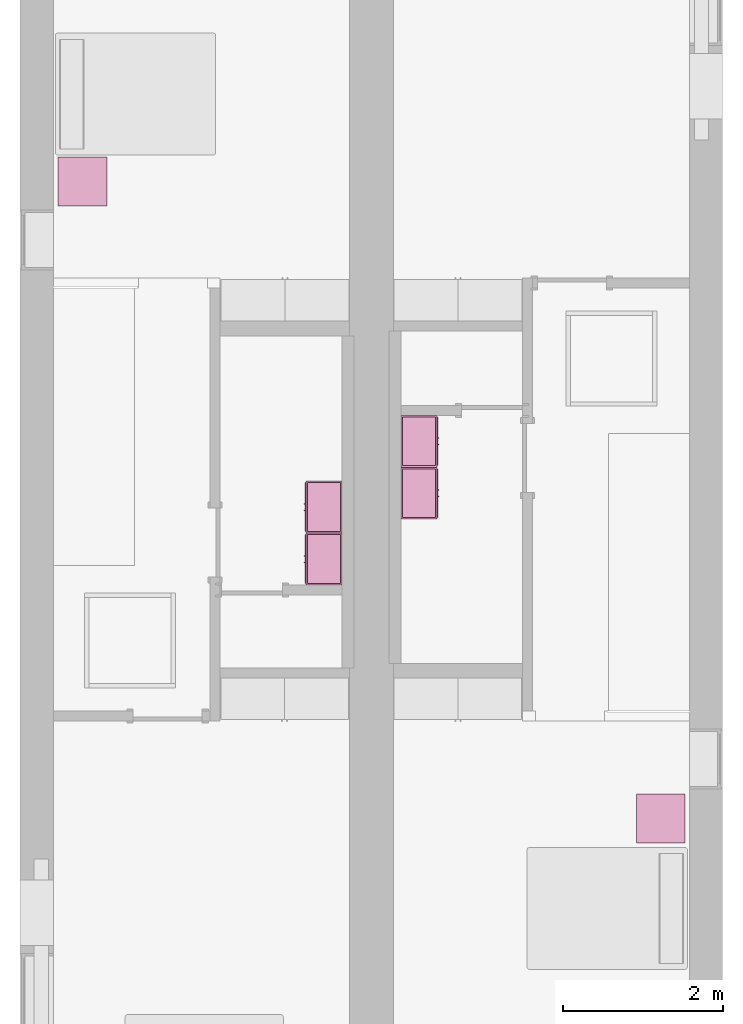
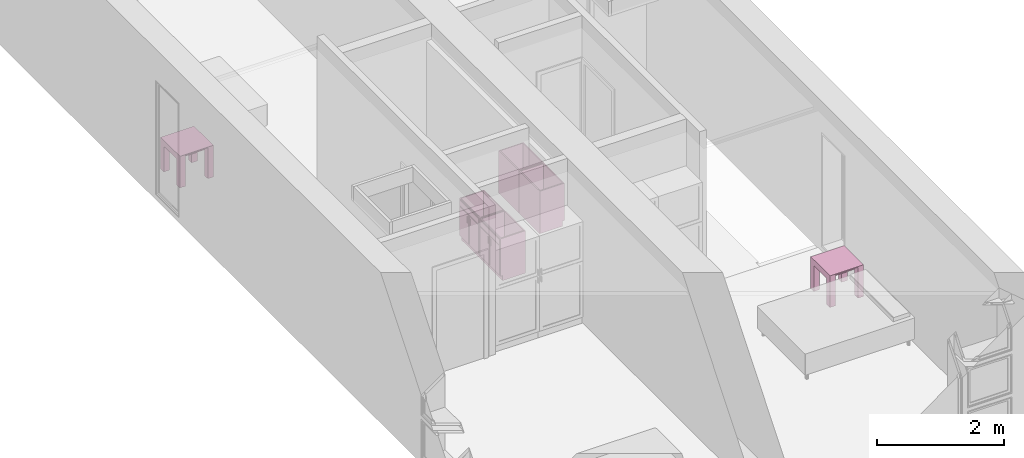
# One storey, part 8 of 12: 6 furnishings.
"""IFC2X3 building model written with IfcOpenShell, lengths in metres."""

import ifcopenshell
import ifcopenshell.guid

model = None  # the IFC model being written
_history = None  # IfcOwnerHistory: only IFC2X3 demands one
_inside = {}  # id of a spatial element -> (the spatial element, [elements in it])
_under = {}  # id of a project, library or spatial element -> (it, [spatial elements below it])
_declared = {}  # id of a project -> (the project, [libraries it declares])
_typed = {}  # id of a type object -> (the type object, [elements of that type])
_made_of = {}  # id of a material, layer set ... -> (it, [elements and type objects made of it])


def new_model(schema):
    """Start an empty IFC model of exactly this schema.

    Asked for "IFC4X3", IfcOpenShell would pick the latest addendum, in which some entities
    have other attributes; the version numbers below select the first issue.
    IFC2X3 requires an IfcOwnerHistory on every rooted entity: one is made here for all.
    """
    global model, _history
    if schema == "IFC4X3":
        model = ifcopenshell.file(schema_version=(4, 3, 0, 0))
    else:
        model = ifcopenshell.file(schema=schema)
    _inside.clear()
    _under.clear()
    _declared.clear()
    _typed.clear()
    _made_of.clear()
    _history = None
    if model.schema == "IFC2X3":
        org = make("IfcOrganization", Name="unknown")
        user = make(
            "IfcPersonAndOrganization",
            ThePerson=make("IfcPerson", FamilyName="unknown"),
            TheOrganization=org,
        )
        app = make(
            "IfcApplication",
            ApplicationDeveloper=org,
            Version="unknown",
            ApplicationFullName="unknown",
            ApplicationIdentifier="unknown",
        )
        _history = make(
            "IfcOwnerHistory",
            OwningUser=user,
            OwningApplication=app,
            ChangeAction="ADDED",
            CreationDate=0,
        )
    return model


def make(cls, **values):
    """One entity of the class cls with the attributes given. An attribute that is None is left unset."""
    return model.create_entity(
        cls, **{name: value for name, value in values.items() if value is not None}
    )


def entity(cls, *values):
    """Any entity or typed value of the class cls, its attributes in the order of the schema. None: left unset."""
    e = model.create_entity(cls)
    for i, value in enumerate(values):
        if value is not None:
            e[i] = value
    return e


def rooted(cls, **values):
    """An entity with a GlobalId (a new one), such as an element, a storey or a relation."""
    return make(cls, GlobalId=ifcopenshell.guid.new(), OwnerHistory=_history, **values)


def si_unit(unit_type, name, prefix=None):
    """IfcSIUnit, for example si_unit("LENGTHUNIT", "METRE", prefix="MILLI")."""
    return make("IfcSIUnit", UnitType=unit_type, Prefix=prefix, Name=name)


def converted_unit(unit_type, name, factor, base, dimensions=None, offset=None):
    """IfcConversionBasedUnit, such as the inch: factor (a typed value) times the base unit."""
    return make(
        "IfcConversionBasedUnit"
        if offset is None
        else "IfcConversionBasedUnitWithOffset",
        ConversionOffset=offset,
        Dimensions=None
        if dimensions is None
        else entity("IfcDimensionalExponents", *dimensions),
        UnitType=unit_type,
        Name=name,
        ConversionFactor=make(
            "IfcMeasureWithUnit", ValueComponent=factor, UnitComponent=base
        ),
    )


def assignment(units):
    """IfcUnitAssignment: the units of a project."""
    return None if units is None else make("IfcUnitAssignment", Units=units)


def point(xyz):
    """IfcCartesianPoint."""
    return None if xyz is None else make("IfcCartesianPoint", Coordinates=xyz)


def direction(xyz):
    """IfcDirection."""
    return None if xyz is None else make("IfcDirection", DirectionRatios=xyz)


def frame(location, z_axis=None, x_axis=None):
    """IfcAxis2Placement3D, a coordinate frame: its origin and axes. An axis left out is left unset."""
    return make(
        "IfcAxis2Placement3D",
        Location=point(location),
        Axis=direction(z_axis),
        RefDirection=direction(x_axis),
    )


def frame_2d(location, x_axis=None):
    """IfcAxis2Placement2D, a coordinate frame in the plane: its origin and x axis."""
    return make(
        "IfcAxis2Placement2D", Location=point(location), RefDirection=direction(x_axis)
    )


def origin():
    """The frame at (0, 0, 0) with its axes left unset."""
    return frame((0.0, 0.0, 0.0))


def origin_2d_with_axis():
    """The frame at (0, 0) in the plane with the x axis (1, 0) written out."""
    return frame_2d((0.0, 0.0), x_axis=(1.0, 0.0))


def place(relative_to, where):
    """IfcLocalPlacement: puts the frame where relative to a parent placement (None: the world)."""
    return make(
        "IfcLocalPlacement", PlacementRelTo=relative_to, RelativePlacement=where
    )


def context(
    kind, dimensions, precision=None, world=None, true_north=None, identifier=None
):
    """IfcGeometricRepresentationContext, for example the 3D "Model" context."""
    return make(
        "IfcGeometricRepresentationContext",
        ContextIdentifier=identifier,
        ContextType=kind,
        CoordinateSpaceDimension=dimensions,
        Precision=precision,
        WorldCoordinateSystem=world,
        TrueNorth=true_north,
    )


def project(units=None, contexts=None):
    """IfcProject with its units and contexts."""
    return rooted(
        "IfcProject",
        Name="project",
        RepresentationContexts=contexts,
        UnitsInContext=assignment(units),
    )


def spatial(cls, under=None, at=None, **own):
    """A site, building, storey or space (cls), placed at a placement, below another one or the project."""
    s = rooted(cls, ObjectPlacement=at, **own)
    if under is not None:
        _under.setdefault(under.id(), (under, []))[1].append(s)
    return s


def polyline(points):
    """IfcPolyline through the points."""
    return make("IfcPolyline", Points=[point(p) for p in points])


def profile(cls, at=None, kind="AREA", **sizes):
    """A parametric profile (cls). Its sizes go by their IFC names, for example OverallWidth=200.0."""
    return make(cls, ProfileType=kind, Position=at, **sizes)


def rectangle(**sizes):
    """IfcRectangleProfileDef."""
    return profile("IfcRectangleProfileDef", **sizes)


def outline(outer, holes=None, kind="AREA"):
    """IfcArbitraryClosedProfileDef: a profile drawn as a closed curve; with holes, ...WithVoids."""
    if holes is None:
        return make("IfcArbitraryClosedProfileDef", ProfileType=kind, OuterCurve=outer)
    return make(
        "IfcArbitraryProfileDefWithVoids",
        ProfileType=kind,
        OuterCurve=outer,
        InnerCurves=holes,
    )


def extrude(swept, where, along, depth):
    """IfcExtrudedAreaSolid: the profile swept, set in the frame where, extruded along a direction by depth."""
    return make(
        "IfcExtrudedAreaSolid",
        SweptArea=swept,
        Position=where,
        ExtrudedDirection=direction(along),
        Depth=depth,
    )


def faces_of(points, faces, orient=None, outer=None):
    """IfcFace entities. A face is a list of loops; a loop is a list of indices into points, from 0.

    orient and outer hold one flag for each loop. By default every Orientation is true, the
    first loop of a face is its IfcFaceOuterBound and the others are IfcFaceBound.
    """
    made = []
    for i, loops in enumerate(faces):
        bounds = []
        for j, loop in enumerate(loops):
            is_outer = j == 0 if outer is None else outer[i][j]
            bounds.append(
                make(
                    "IfcFaceOuterBound" if is_outer else "IfcFaceBound",
                    Bound=make("IfcPolyLoop", Polygon=[points[k] for k in loop]),
                    Orientation=True if orient is None else orient[i][j],
                )
            )
        made.append(make("IfcFace", Bounds=bounds))
    return made


def face_set(faces, orient=None, outer=None):
    """The faces of one IfcConnectedFaceSet. surface_model builds it on its shared points."""
    return ("IfcConnectedFaceSet", faces, orient, outer)


def surface_model(cls, points, shells):
    """IfcFaceBasedSurfaceModel or IfcShellBasedSurfaceModel (cls): surfaces that need not close."""
    shared = [point(p) for p in points]
    made = [make(c, CfsFaces=faces_of(shared, fs, o, b)) for c, fs, o, b in shells]
    if cls == "IfcFaceBasedSurfaceModel":
        return make(cls, FbsmFaces=made)
    return make(cls, SbsmBoundary=made)


def shape(context_of_items, identifier, shape_type, items):
    """IfcShapeRepresentation: the items that make up one representation, for example the "Body"."""
    return make(
        "IfcShapeRepresentation",
        ContextOfItems=context_of_items,
        RepresentationIdentifier=identifier,
        RepresentationType=shape_type,
        Items=items,
    )


def source(mapping_origin, context_of_items, identifier, shape_type, items):
    """IfcRepresentationMap: a shape defined once, which mapped items show again and again."""
    return make(
        "IfcRepresentationMap",
        MappingOrigin=mapping_origin,
        MappedRepresentation=shape(context_of_items, identifier, shape_type, items),
    )


def transform(
    local_origin,
    x_axis=None,
    y_axis=None,
    z_axis=None,
    scale=None,
    scale2=None,
    scale3=None,
    uniform=True,
):
    """IfcCartesianTransformationOperator3D, or its non-uniform kind. x_axis, y_axis, z_axis: its Axis1, 2, 3."""
    if uniform:
        return make(
            "IfcCartesianTransformationOperator3D",
            Axis1=direction(x_axis),
            Axis2=direction(y_axis),
            LocalOrigin=point(local_origin),
            Scale=scale,
            Axis3=direction(z_axis),
        )
    return make(
        "IfcCartesianTransformationOperator3DnonUniform",
        Axis1=direction(x_axis),
        Axis2=direction(y_axis),
        LocalOrigin=point(local_origin),
        Scale=scale,
        Axis3=direction(z_axis),
        Scale2=scale2,
        Scale3=scale3,
    )


def mapped(mapping_source, mapping_target):
    """IfcMappedItem: shows the shape of a source again, moved by a transform."""
    return make(
        "IfcMappedItem", MappingSource=mapping_source, MappingTarget=mapping_target
    )


def made_of(thing, what):
    """Note that an element or type object is made of a material, layer set ...; save() writes the relation."""
    if what is not None:
        _made_of.setdefault(what.id(), (what, []))[1].append(thing)
    return thing


def type_object(cls, material=None, **own):
    """A type object (cls), such as IfcWallType, which elements share."""
    return made_of(rooted(cls, **own), material)


def type_shapes(of_type, sources):
    """Give a type object the sources (RepresentationMaps) that its elements show as mapped items."""
    of_type.RepresentationMaps = sources


def element(
    cls,
    number,
    at=None,
    inside=None,
    cuts=None,
    type_object=None,
    material=None,
    context=None,
    identifier="Body",
    shape_type=None,
    held_by="IfcProductDefinitionShape",
    body=None,
    shapes=None,
    **own,
):
    """One element of the class cls, such as IfcWall. Its Tag is "e" and its number.

    at: its placement. inside: the storey or other place that contains it. cuts: it is an
    opening in that element (IfcRelVoidsElement). A single representation is given by context,
    identifier, shape_type and body (its items); several are given by shapes. held_by: the class
    of the entity that holds the representations. save() writes the other relations.
    """
    e = rooted(cls, Tag="e%d" % number, ObjectPlacement=at, **own)
    if body is not None:
        shapes = [shape(context, identifier, shape_type, body)]
    if shapes is not None:
        e.Representation = make(held_by, Representations=shapes)
    if inside is not None:
        _inside.setdefault(inside.id(), (inside, []))[1].append(e)
    if cuts is not None:
        rooted(
            "IfcRelVoidsElement", RelatingBuildingElement=cuts, RelatedOpeningElement=e
        )
    if type_object is not None:
        _typed.setdefault(type_object.id(), (type_object, []))[1].append(e)
    return made_of(e, material)


def aggregate(whole, parts):
    """IfcRelAggregates: a whole, such as a stair, and the parts it consists of."""
    return rooted("IfcRelAggregates", RelatingObject=whole, RelatedObjects=parts)


def save(model, path):
    """Write the relations noted so far, then the file.

    IfcRelAggregates (storeys below a building ...), IfcRelContainedInSpatialStructure (elements
    in a storey), IfcRelDefinesByType, IfcRelAssociatesMaterial and IfcRelDeclares: one each for
    every whole, place, type object, material and project.
    """
    for whole, parts in _under.values():
        aggregate(whole, parts)
    for where, things in _inside.values():
        rooted(
            "IfcRelContainedInSpatialStructure",
            RelatedElements=things,
            RelatingStructure=where,
        )
    for kind, things in _typed.values():
        rooted("IfcRelDefinesByType", RelatedObjects=things, RelatingType=kind)
    for what, things in _made_of.values():
        rooted("IfcRelAssociatesMaterial", RelatedObjects=things, RelatingMaterial=what)
    for by, libraries in _declared.values():
        rooted("IfcRelDeclares", RelatingContext=by, RelatedDefinitions=libraries)
    model.write(path)


model = new_model("IFC2X3")

# Units and contexts
model_context = context("Model", 3, precision=1e-09, world=origin())
plan_context = context("Plan", 3, precision=1e-09, world=origin())
ifc_project = project(units=[si_unit("LENGTHUNIT", "METRE"), si_unit("AREAUNIT", "SQUARE_METRE"), si_unit("VOLUMEUNIT", "CUBIC_METRE"), converted_unit("PLANEANGLEUNIT", "DEGREE", entity("IfcRatioMeasure", 0.0174532925199433), si_unit("PLANEANGLEUNIT", "RADIAN"), dimensions=[0, 0, 0, 0, 0, 0, 0]), si_unit("TIMEUNIT", "SECOND")], contexts=[model_context, plan_context])

# Site, building, storey, space
site_placement = place(None, origin())
site = spatial("IfcSite", under=ifc_project, at=site_placement, CompositionType="ELEMENT")
building_placement = place(site_placement, origin())
building = spatial("IfcBuilding", under=site, at=building_placement, CompositionType="ELEMENT")
storey_placement = place(building_placement, frame((0.0, 0.0, 3.10000000000038)))
storey = spatial("IfcBuildingStorey", under=building, at=storey_placement, Name="Level 2", CompositionType="ELEMENT", Elevation=3.10000000000038)
space_1_placement = place(storey_placement, origin())
space_1 = spatial("IfcSpace", under=storey, at=space_1_placement, CompositionType="ELEMENT", InteriorOrExteriorSpace="INTERNAL")

# Furnishing
furniture_type_1 = type_object("IfcFurnitureType", Name="0610 x 0610 x 0610mm", AssemblyPlace="NOTDEFINED")
shared_shape_1 = source(origin(), model_context, "Body", "SweptSolid", [
    extrude(rectangle(XDim=0.406799999999999, YDim=0.406799999999999, at=origin_2d_with_axis()), frame((0.0182657666726316, 0.0952110778022263, 0.4957), z_axis=(0.0, 0.0, 1.0), x_axis=(-1.0, 0.0, 0.0)), (0.0, 0.0, 1.0), 0.0127),
    extrude(outline(polyline([(-0.273249999999994, -0.305), (0.324049999999978, -0.305), (0.324049999999978, 0.304999999999998), (-0.273249999999993, 0.304999999999999), (-0.273249999999993, 0.203400000000001), (0.222450000000009, 0.203400000000001), (0.222450000000009, -0.2034), (-0.273249999999994, -0.2034), (-0.273249999999994, -0.305)])), frame((0.221665766672633, 0.0952110778022354, 0.273249999999992), z_axis=(1.0, 0.0, 0.0), x_axis=(0.0, 0.0, 1.0)), (0.0, 0.0, 1.0), 0.1016),
    extrude(outline(polyline([(-0.305000000000004, -0.324050000000025), (0.304999999999994, -0.324050000000025), (0.304999999999994, 0.273250000000011), (0.203400000000004, 0.273250000000011), (0.203400000000004, -0.222449999999996), (-0.203399999999995, -0.222449999999996), (-0.203399999999995, 0.273250000000011), (-0.305000000000004, 0.273250000000011), (-0.305000000000004, -0.324050000000025)])), frame((-0.286734233327367, 0.0952110778022256, 0.273250000000008), z_axis=(1.0, 0.0, 0.0), x_axis=(0.0, -1.0, 0.0)), (0.0, 0.0, 1.0), 0.1016),
    extrude(rectangle(XDim=0.406799999999999, YDim=0.406799999999999, at=origin_2d_with_axis()), frame((0.0182657666726316, 0.0952110778022259, 0.5973), z_axis=(0.0, 0.0, 1.0), x_axis=(-1.0, 0.0, 0.0)), (0.0, 0.0, 1.0), 0.0127),
    extrude(outline(polyline([(-0.305, -0.305000000000023), (0.305, -0.305000000000023), (0.305, 0.305000000000023), (-0.305, 0.305000000000023), (-0.305, -0.305000000000023)]), holes=[polyline([(-0.203399999999998, -0.203399999999975), (-0.203399999999998, 0.203400000000025), (0.203400000000001, 0.203400000000025), (0.203400000000001, -0.203399999999975), (-0.203399999999998, -0.203399999999975)])]), frame((0.0182657666726332, 0.0952110778022508, 0.5973), z_axis=(0.0, 0.0, 1.0), x_axis=(-1.0, 0.0, 0.0)), (0.0, 0.0, 1.0), 0.0127),
])
type_shapes(furniture_type_1, [shared_shape_1])
furnishing_1_placement = place(space_1_placement, frame((0.763734233327367, -5.01221107780223, 0.0189999999998181)))
element("IfcFurnishingElement", 1, at=furnishing_1_placement, inside=space_1, type_object=furniture_type_1, Name="M_Table-Coffee:0610 x 0610 x 0610mm:0610 x 0610 x 0610mm", ObjectType="0610 x 0610 x 0610mm", context=model_context, shape_type="MappedRepresentation", body=[
    mapped(shared_shape_1, transform((0.0, 0.0, 0.0), scale=1.0)),
])

# Space
space_2_placement = place(storey_placement, origin())
space_2 = spatial("IfcSpace", under=storey, at=space_2_placement, CompositionType="ELEMENT", InteriorOrExteriorSpace="INTERNAL")

# Furnishing
furnishing_2_placement = place(space_2_placement, frame((8.00473423332735, -12.9892110778022, 0.0189999999998181)))
element("IfcFurnishingElement", 2, at=furnishing_2_placement, inside=space_2, type_object=furniture_type_1, Name="M_Table-Coffee:0610 x 0610 x 0610mm:0610 x 0610 x 0610mm", ObjectType="0610 x 0610 x 0610mm", context=model_context, shape_type="MappedRepresentation", body=[
    mapped(shared_shape_1, transform((0.0, 0.0, 0.0), scale=1.0)),
])

# Space
space_3_placement = place(storey_placement, origin())
space_3 = spatial("IfcSpace", under=storey, at=space_3_placement, CompositionType="ELEMENT", InteriorOrExteriorSpace="INTERNAL")

# Furnishings
furniture_type_2 = type_object("IfcFurnitureType", Name="650 x 450 mm", AssemblyPlace="NOTDEFINED")
shared_shape_2 = source(origin(), model_context, "Body", "SurfaceModel", [
    surface_model("IfcFaceBasedSurfaceModel", [(0.630950000000001, 0.044449999999999, 0.82), (0.630950000000001, 0.044449999999999, 0.0999999999999995), (0.0190499999999987, 0.044449999999999, 0.0999999999999995), (0.0190499999999987, 0.044449999999999, 0.82), (0.65, 0.0254000000000003, 0.82), (0.0, 0.0254000000000003, 0.82), (0.65, 0.0254000000000003, 0.0999999999999995), (0.0, 0.0254000000000003, 0.0999999999999995), (0.0190499999999987, 0.456350000000001, 0.82), (0.0190499999999987, 0.456350000000001, 0.0999999999999994), (0.0190499999999987, 0.0604000000000022, 0.0999999999999995), (0.0, 0.4754, 0.82), (0.0, 0.4754, 0.0), (0.0, 0.0604000000000022, 0.0), (0.0, 0.0604000000000022, 0.0999999999999994), (0.630950000000001, 0.456350000000001, 0.82), (0.630950000000001, 0.456350000000001, 0.0999999999999994), (0.65, 0.4754, 0.82), (0.65, 0.4754, 0.0), (0.630950000000001, 0.0604000000000022, 0.0999999999999994), (0.65, 0.0604000000000022, 0.0999999999999995), (0.65, 0.0604000000000022, 0.0), (0.290074999999999, 0.0, 0.642200000000001), (0.290074999999999, 0.0, 0.517469895035161), (0.277374999999999, 0.0, 0.517469895035161), (0.277374999999999, 0.0, 0.642200000000001), (0.372624999999921, 0.0, 0.642200000000001), (0.372624999999921, 0.0, 0.517469895035163), (0.359924999999921, 0.0, 0.517469895035163), (0.359924999999921, 0.0, 0.642200000000001), (0.290074999999999, 0.0127000000000003, 0.642200000000001), (0.290074999999999, 0.0127000000000003, 0.517469895035161), (0.277374999999999, 0.0127000000000004, 0.517469895035161), (0.277374999999999, 0.0127000000000004, 0.642200000000001), (0.372624999999921, 0.0127, 0.642200000000001), (0.372624999999921, 0.0127, 0.517469895035163), (0.359924999999921, 0.0127000000000001, 0.517469895035163), (0.359924999999921, 0.0127000000000001, 0.642200000000001), (0.315474999999897, 0.0127000000000003, 0.680300000000006), (0.315474999999897, 0.0127000000000003, 0.119049999999842), (0.0190500000004793, 0.0127000000000012, 0.119049999999842), (0.0190500000004793, 0.0127000000000012, 0.680300000000006), (0.630950000000507, 0.0126999999999993, 0.680300000000043), (0.630950000000507, 0.0126999999999993, 0.119049999999857), (0.334524999999847, 0.0127000000000002, 0.119049999999857), (0.334524999999847, 0.0127000000000002, 0.680300000000043), (0.63095000000051, 0.0126999999999993, 0.800950000000086), (0.63095000000051, 0.0126999999999993, 0.699350000000061), (0.0190500000004913, 0.0127000000000012, 0.699350000000061), (0.0190500000004912, 0.0127000000000012, 0.800950000000086), (0.315474999999897, 0.0254000000000003, 0.680300000000006), (0.315474999999897, 0.0254000000000003, 0.119049999999842), (0.0190500000004793, 0.0254000000000013, 0.119049999999842), (0.0190500000004793, 0.0254000000000013, 0.680300000000006), (0.630950000000507, 0.0253999999999993, 0.680300000000043), (0.630950000000507, 0.0253999999999993, 0.119049999999857), (0.334524999999847, 0.0254000000000002, 0.119049999999857), (0.334524999999847, 0.0254000000000002, 0.680300000000043), (0.63095000000051, 0.0253999999999993, 0.800950000000086), (0.63095000000051, 0.0253999999999993, 0.699350000000061), (0.0190500000004914, 0.0254000000000013, 0.699350000000061), (0.0190500000004913, 0.0254000000000013, 0.800950000000086), (0.630950000000001, 0.456350000000001, 0.119049999999842), (0.630950000000001, 0.044449999999999, 0.119049999999842), (0.0190499999999987, 0.044449999999999, 0.119049999999842), (0.0190499999999987, 0.456350000000001, 0.119049999999842), (0.630950000000001, 0.456350000000001, 0.0999999999999994), (0.630950000000001, 0.044449999999999, 0.0999999999999994), (0.0190499999999987, 0.044449999999999, 0.0999999999999994), (0.0190499999999987, 0.456350000000001, 0.0999999999999994)], [face_set([[[0, 1, 2, 3]], [[0, 4, 5, 3]], [[4, 6, 7, 5]], [[2, 1, 6, 7]], [[3, 8, 9, 10, 2]], [[5, 11, 8, 3]], [[7, 5, 11, 12, 13, 14]], [[2, 7, 14, 10]], [[8, 15, 16, 9]], [[11, 17, 15, 8]], [[12, 11, 17, 18]], [[1, 19, 16, 15, 0]], [[0, 15, 17, 4]], [[4, 6, 20, 21, 18, 17]], [[6, 1, 19, 20]], [[10, 9, 16, 19]], [[18, 21, 13, 12]], [[13, 14, 10, 19, 20, 21]]]), face_set([[[22, 23, 24, 25]], [[26, 27, 28, 29]], [[30, 31, 32, 33]], [[34, 35, 36, 37]], [[25, 33, 30, 22]], [[24, 32, 33, 25]], [[23, 24, 32, 31]], [[22, 23, 31, 30]], [[29, 37, 34, 26]], [[28, 36, 37, 29]], [[27, 28, 36, 35]], [[26, 27, 35, 34]]]), face_set([[[38, 39, 40, 41]], [[42, 43, 44, 45]], [[46, 47, 48, 49]], [[50, 51, 52, 53]], [[54, 55, 56, 57]], [[58, 59, 60, 61]], [[41, 53, 50, 38]], [[40, 41, 53, 52]], [[39, 40, 52, 51]], [[38, 39, 51, 50]], [[45, 57, 54, 42]], [[44, 56, 57, 45]], [[43, 44, 56, 55]], [[42, 43, 55, 54]], [[49, 61, 58, 46]], [[48, 49, 61, 60]], [[47, 48, 60, 59]], [[46, 47, 59, 58]]]), face_set([[[62, 63, 64, 65]], [[66, 67, 68, 69]], [[65, 62, 66, 69]], [[64, 65, 69, 68]], [[63, 67, 68, 64]], [[62, 63, 67, 66]]])]),
])
type_shapes(furniture_type_2, [shared_shape_2])
for number, where, z_axis, x_axis in (
    (3, (3.55459999999998, -9.32005117851059, 0.0129999999998178), (0.0, 0.0, 1.0), (0.0, -1.0, 0.0)),
    (4, (3.55459999999999, -8.67005117851059, 0.0129999999998178), (0.0, 0.0, 1.0), (0.0, -1.0, 0.0)),
):
    element("IfcFurnishingElement", number, at=place(space_3_placement, frame(where, z_axis=z_axis, x_axis=x_axis)), inside=space_3, type_object=furniture_type_2, ObjectType="650 x 450 mm", context=model_context, shape_type="MappedRepresentation", body=[
        mapped(shared_shape_2, transform((0.0, 0.0, 0.0), scale=1.0)),
    ])

# Space
space_4_placement = place(storey_placement, origin())
space_4 = spatial("IfcSpace", under=storey, at=space_4_placement, CompositionType="ELEMENT", InteriorOrExteriorSpace="INTERNAL")

# Furnishings
furniture_type_3 = type_object("IfcFurnitureType", Name="650 x 450 mm", AssemblyPlace="NOTDEFINED")
shared_shape_3 = source(origin(), model_context, "Body", "SurfaceModel", [
    surface_model("IfcFaceBasedSurfaceModel", [(0.630950000000001, 0.430950000000001, 0.82), (0.0190499999999987, 0.430950000000001, 0.82), (0.0190499999999987, 0.430950000000001, 0.0999999999999995), (0.630950000000001, 0.430950000000001, 0.0999999999999995), (0.0, 0.45, 0.82), (0.65, 0.45, 0.82), (0.0, 0.45, 0.0999999999999995), (0.65, 0.45, 0.0999999999999995), (0.0190499999999987, 0.414999999999998, 0.0999999999999994), (0.0190499999999987, 0.0190499999999987, 0.0999999999999995), (0.0190499999999987, 0.0190499999999987, 0.82), (0.0, 0.0, 0.82), (0.0, 0.0, 0.0), (0.0, 0.414999999999998, 0.0), (0.0, 0.414999999999998, 0.0999999999999995), (0.630950000000001, 0.0190499999999987, 0.0999999999999995), (0.630950000000001, 0.0190499999999987, 0.82), (0.65, 0.0, 0.82), (0.65, 0.0, 0.0), (0.630950000000001, 0.414999999999998, 0.0999999999999995), (0.65, 0.414999999999998, 0.0), (0.65, 0.414999999999998, 0.0999999999999995), (0.290074999999999, 0.4754, 0.642200000000001), (0.277374999999999, 0.4754, 0.642200000000001), (0.277374999999999, 0.4754, 0.517469895035161), (0.290074999999999, 0.4754, 0.517469895035161), (0.372624999999921, 0.4754, 0.642200000000001), (0.359924999999921, 0.4754, 0.642200000000001), (0.359924999999921, 0.4754, 0.517469895035163), (0.372624999999921, 0.4754, 0.517469895035163), (0.290074999999999, 0.4627, 0.642200000000001), (0.277374999999999, 0.4627, 0.642200000000001), (0.277374999999999, 0.4627, 0.517469895035161), (0.290074999999999, 0.4627, 0.517469895035161), (0.372624999999921, 0.4627, 0.642200000000001), (0.359924999999921, 0.4627, 0.642200000000001), (0.359924999999921, 0.4627, 0.517469895035163), (0.372624999999921, 0.4627, 0.517469895035163), (0.315474999999897, 0.4627, 0.680300000000006), (0.0190500000004793, 0.462699999999999, 0.680300000000006), (0.0190500000004793, 0.462699999999999, 0.119049999999842), (0.315474999999897, 0.4627, 0.119049999999842), (0.630950000000507, 0.462700000000001, 0.680300000000043), (0.334524999999847, 0.4627, 0.680300000000043), (0.334524999999847, 0.4627, 0.119049999999857), (0.630950000000507, 0.462700000000001, 0.119049999999857), (0.63095000000051, 0.462700000000001, 0.800950000000086), (0.0190500000004913, 0.462699999999999, 0.800950000000086), (0.0190500000004912, 0.462699999999999, 0.699350000000061), (0.63095000000051, 0.462700000000001, 0.699350000000061), (0.315474999999897, 0.45, 0.680300000000006), (0.0190500000004793, 0.449999999999999, 0.680300000000006), (0.0190500000004793, 0.449999999999999, 0.119049999999842), (0.315474999999897, 0.45, 0.119049999999842), (0.630950000000507, 0.450000000000001, 0.680300000000043), (0.334524999999847, 0.45, 0.680300000000043), (0.334524999999847, 0.45, 0.119049999999857), (0.630950000000507, 0.450000000000001, 0.119049999999857), (0.63095000000051, 0.450000000000001, 0.800950000000086), (0.0190500000004914, 0.449999999999999, 0.800950000000086), (0.0190500000004913, 0.449999999999999, 0.699350000000061), (0.63095000000051, 0.450000000000001, 0.699350000000061), (0.630950000000001, 0.0190499999999987, 0.119049999999842), (0.0190499999999987, 0.0190499999999987, 0.119049999999842), (0.0190499999999987, 0.430950000000001, 0.119049999999842), (0.630950000000001, 0.430950000000001, 0.119049999999842), (0.630950000000001, 0.0190499999999987, 0.0999999999999994), (0.0190499999999987, 0.0190499999999987, 0.0999999999999994), (0.0190499999999987, 0.430950000000001, 0.0999999999999994), (0.630950000000001, 0.430950000000001, 0.0999999999999994)], [face_set([[[0, 1, 2, 3]], [[0, 1, 4, 5]], [[5, 4, 6, 7]], [[2, 6, 7, 3]], [[1, 2, 8, 9, 10]], [[4, 1, 10, 11]], [[6, 4, 11, 12, 13, 14]], [[2, 8, 14, 6]], [[10, 9, 15, 16]], [[11, 10, 16, 17]], [[12, 18, 17, 11]], [[3, 0, 16, 15, 19]], [[0, 5, 17, 16]], [[5, 17, 18, 20, 21, 7]], [[7, 21, 19, 3]], [[8, 19, 15, 9]], [[18, 12, 13, 20]], [[13, 20, 21, 19, 8, 14]]]), face_set([[[22, 23, 24, 25]], [[26, 27, 28, 29]], [[30, 31, 32, 33]], [[34, 35, 36, 37]], [[23, 22, 30, 31]], [[24, 23, 31, 32]], [[25, 33, 32, 24]], [[22, 30, 33, 25]], [[27, 26, 34, 35]], [[28, 27, 35, 36]], [[29, 37, 36, 28]], [[26, 34, 37, 29]]]), face_set([[[38, 39, 40, 41]], [[42, 43, 44, 45]], [[46, 47, 48, 49]], [[50, 51, 52, 53]], [[54, 55, 56, 57]], [[58, 59, 60, 61]], [[39, 38, 50, 51]], [[40, 52, 51, 39]], [[41, 53, 52, 40]], [[38, 50, 53, 41]], [[43, 42, 54, 55]], [[44, 43, 55, 56]], [[45, 57, 56, 44]], [[42, 54, 57, 45]], [[47, 46, 58, 59]], [[48, 60, 59, 47]], [[49, 61, 60, 48]], [[46, 58, 61, 49]]]), face_set([[[62, 63, 64, 65]], [[66, 67, 68, 69]], [[63, 67, 66, 62]], [[64, 68, 67, 63]], [[65, 64, 68, 69]], [[62, 66, 69, 65]]])]),
])
type_shapes(furniture_type_3, [shared_shape_3])
for number, where, z_axis, x_axis in (
    (5, (4.77000000000002, -8.49538423507153, 0.0129999999998178), (0.0, 0.0, 1.0), (0.0, -1.0, 0.0)),
    (6, (4.77000000000001, -7.84538423507153, 0.0129999999998178), (0.0, 0.0, 1.0), (0.0, -1.0, 0.0)),
):
    element("IfcFurnishingElement", number, at=place(space_4_placement, frame(where, z_axis=z_axis, x_axis=x_axis)), inside=space_4, type_object=furniture_type_3, ObjectType="650 x 450 mm", context=model_context, shape_type="MappedRepresentation", body=[
        mapped(shared_shape_3, transform((0.0, 0.0, 0.0), scale=1.0)),
    ])

save(model, "model.ifc")
